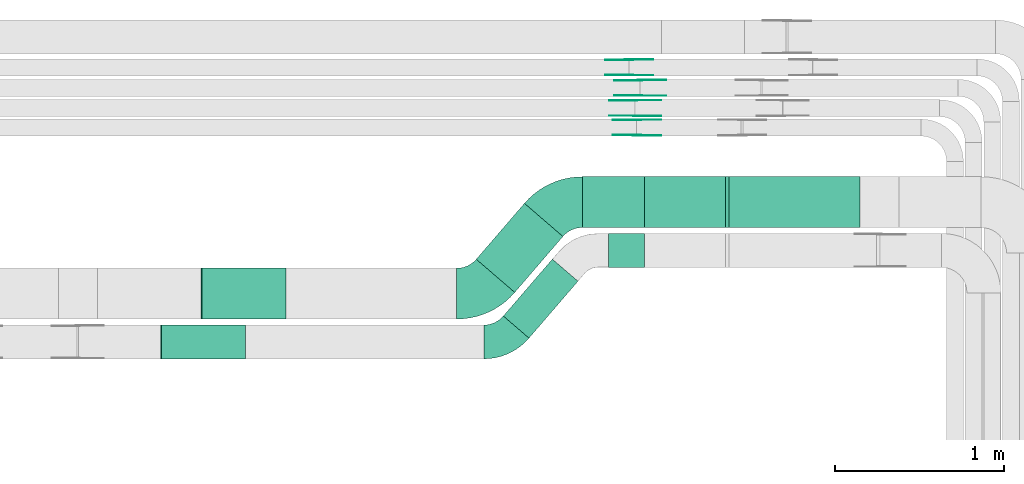
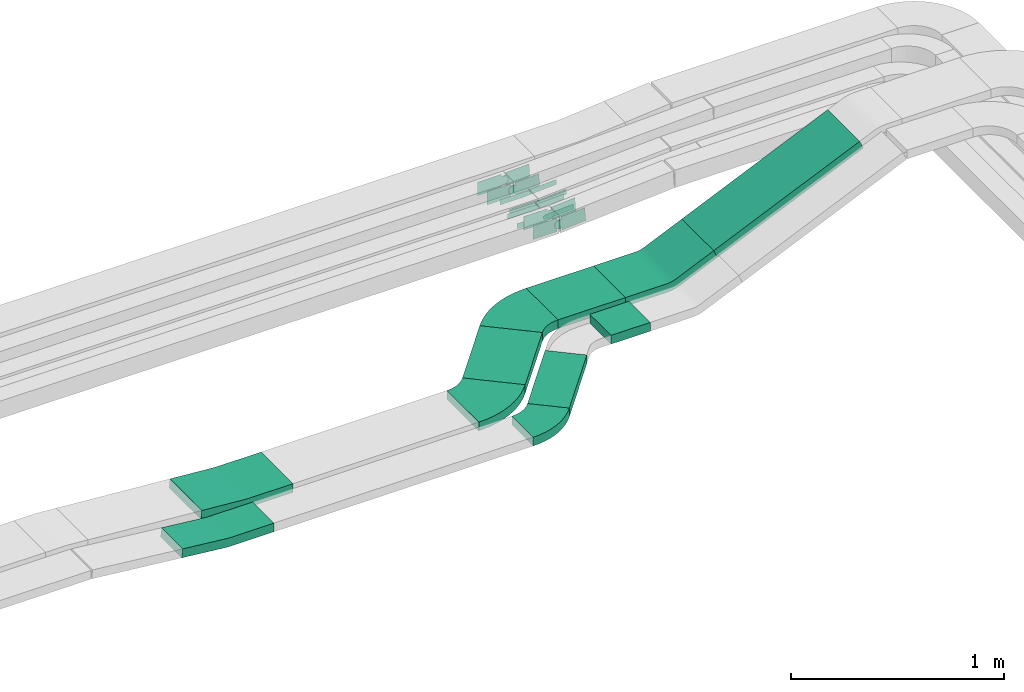
# One storey, part 22 of 31: 22 flow fittings, 5 flow segments.
"""IFC2X3 building model written with IfcOpenShell, lengths in millimetres."""

from ifc_helpers import new_model, entity, si_unit, converted_unit, derived_unit, direction, frame, frame_2d, origin, place, context, subcontext, project, spatial, polyline, circle_curve, parameter, trimmed, segment, composite_curve, rectangle, outline, extrude, source, transform, mapped, material, type_object, type_shapes, element, save


model = new_model("IFC2X3")

# Units and contexts
model_context = context("Model", 3, precision=0.01, world=origin(), true_north=direction((6.12303176911189e-17, 1.0)))
body_context = subcontext(model_context, "Body", "Model", "MODEL_VIEW")
ifc_project = project(units=[si_unit("LENGTHUNIT", "METRE", prefix="MILLI"), si_unit("AREAUNIT", "SQUARE_METRE"), si_unit("VOLUMEUNIT", "CUBIC_METRE"), converted_unit("PLANEANGLEUNIT", "DEGREE", entity("IfcRatioMeasure", 0.0174532925199433), si_unit("PLANEANGLEUNIT", "RADIAN"), dimensions=[0, 0, 0, 0, 0, 0, 0]), si_unit("MASSUNIT", "GRAM", prefix="KILO"), derived_unit("MASSDENSITYUNIT", [(si_unit("MASSUNIT", "GRAM", prefix="KILO"), 1), (si_unit("LENGTHUNIT", "METRE"), -3)]), derived_unit("MOMENTOFINERTIAUNIT", [(si_unit("LENGTHUNIT", "METRE"), 4)]), si_unit("TIMEUNIT", "SECOND"), si_unit("FREQUENCYUNIT", "HERTZ"), si_unit("THERMODYNAMICTEMPERATUREUNIT", "DEGREE_CELSIUS"), derived_unit("THERMALTRANSMITTANCEUNIT", [(si_unit("MASSUNIT", "GRAM", prefix="KILO"), 1), (si_unit("THERMODYNAMICTEMPERATUREUNIT", "KELVIN"), -1), (si_unit("TIMEUNIT", "SECOND"), -3)]), derived_unit("VOLUMETRICFLOWRATEUNIT", [(si_unit("LENGTHUNIT", "METRE"), 3), (si_unit("TIMEUNIT", "SECOND"), -1)]), derived_unit("MASSFLOWRATEUNIT", [(si_unit("MASSUNIT", "GRAM", prefix="KILO"), 1), (si_unit("TIMEUNIT", "SECOND"), -1)]), derived_unit("ROTATIONALFREQUENCYUNIT", [(si_unit("TIMEUNIT", "SECOND"), -1)]), si_unit("ELECTRICCURRENTUNIT", "AMPERE"), si_unit("ELECTRICVOLTAGEUNIT", "VOLT"), si_unit("POWERUNIT", "WATT"), si_unit("FORCEUNIT", "NEWTON", prefix="KILO"), si_unit("ILLUMINANCEUNIT", "LUX"), si_unit("LUMINOUSFLUXUNIT", "LUMEN"), si_unit("LUMINOUSINTENSITYUNIT", "CANDELA"), derived_unit("USERDEFINED", [(si_unit("MASSUNIT", "GRAM", prefix="KILO"), -1), (si_unit("LENGTHUNIT", "METRE"), -2), (si_unit("TIMEUNIT", "SECOND"), 3), (si_unit("LUMINOUSFLUXUNIT", "LUMEN"), 1)]), derived_unit("LINEARVELOCITYUNIT", [(si_unit("LENGTHUNIT", "METRE"), 1), (si_unit("TIMEUNIT", "SECOND"), -1)]), si_unit("PRESSUREUNIT", "PASCAL"), derived_unit("USERDEFINED", [(si_unit("LENGTHUNIT", "METRE"), -2), (si_unit("MASSUNIT", "GRAM", prefix="KILO"), 1), (si_unit("TIMEUNIT", "SECOND"), -2)]), derived_unit("LINEARFORCEUNIT", [(si_unit("MASSUNIT", "GRAM", prefix="KILO"), 1), (si_unit("LENGTHUNIT", "METRE"), 1), (si_unit("TIMEUNIT", "SECOND"), -2), (si_unit("LENGTHUNIT", "METRE"), -1)]), derived_unit("PLANARFORCEUNIT", [(si_unit("MASSUNIT", "GRAM", prefix="KILO"), 1), (si_unit("LENGTHUNIT", "METRE"), 1), (si_unit("TIMEUNIT", "SECOND"), -2), (si_unit("LENGTHUNIT", "METRE"), -2)])], contexts=[model_context])

# Site, building, storey
site_placement = place(None, frame((0.0, -0.00077364408347762, 0.0)))
site = spatial("IfcSite", under=ifc_project, at=site_placement, CompositionType="ELEMENT")
building_placement = place(site_placement, origin())
building = spatial("IfcBuilding", under=site, at=building_placement, CompositionType="ELEMENT")
storey_placement = place(building_placement, frame((0.0, 0.0, 15900.0)))
storey = spatial("IfcBuildingStorey", under=building, at=storey_placement, CompositionType="ELEMENT", Elevation=15900.0)

# Flow segments
cable_carrier_segment_type = type_object("IfcCableCarrierSegmentType", PredefinedType="CABLETRAYSEGMENT")
flow_segment_1_placement = place(storey_placement, frame((57977.730040045, 14975.0255085139, 2510.0)))
element("IfcFlowSegment", 1, at=flow_segment_1_placement, inside=storey, type_object=cable_carrier_segment_type, context=body_context, shape_type="SweptSolid", body=[
    extrude(rectangle(XDim=365.580974619781, YDim=300.000000000001, at=frame_2d((4.33431068813661e-12, -1.08002495835535e-12), x_axis=(1.0, 0.0))), frame((182.790487309981, 150.0, 0.0)), (0.0, 0.0, 1.0), 50.0000000000016),
])
flow_segment_2_placement = place(storey_placement, frame((58129.8647106029, 14740.0255085138, 2510.0)))
element("IfcFlowSegment", 2, at=flow_segment_2_placement, inside=storey, type_object=cable_carrier_segment_type, context=body_context, shape_type="SweptSolid", body=[
    extrude(rectangle(XDim=213.446304058507, YDim=200.000000000002, at=frame_2d((-4.32720526077901e-12, 2.16715534406831e-12), x_axis=(1.0, 0.0))), frame((106.723152029249, 100.0, 1.08286712929839e-09), z_axis=(0.0, 0.0, 1.0), x_axis=(-1.0, 0.0, 0.0)), (0.0, 0.0, 1.0), 50.0000000000016),
])
flow_segment_3_placement = place(storey_placement, frame((58823.1038131155, 14975.0255085139, 2615.53742369649)))
element("IfcFlowSegment", 3, at=flow_segment_3_placement, inside=storey, type_object=cable_carrier_segment_type, context=body_context, shape_type="SweptSolid", body=[
    extrude(rectangle(XDim=50.0000000000058, YDim=300.000000000001, at=frame_2d((0.0, 1.98063787593128e-12), x_axis=(0.0, 1.0))), frame((10.103600774682, 150.0, 22.8673840083723), z_axis=(0.914695360334615, 0.0, 0.404144030986887), x_axis=(0.0, 1.0, 0.0)), (0.0, 0.0, 1.0), 866.474738056523),
])
flow_segment_4_placement = place(storey_placement, frame((57350.8864609675, 14592.1327446923, 2510.0)))
element("IfcFlowSegment", 4, at=flow_segment_4_placement, inside=storey, type_object=cable_carrier_segment_type, context=body_context, shape_type="SweptSolid", body=[
    extrude(rectangle(XDim=435.530076428594, YDim=300.000000000003, at=frame_2d((8.24229573481716e-13, 6.96331881044898e-13), x_axis=(1.0, 0.0))), frame((255.765017222242, 262.892763821559, 0.0), z_axis=(0.0, 0.0, 1.0), x_axis=(-0.652556674980556, -0.757739919720692, 0.0)), (0.0, 0.0, 1.0), 50.0000000000016),
])
flow_segment_5_placement = place(storey_placement, frame((57510.667175223, 14322.3884121903, 2510.0)))
element("IfcFlowSegment", 5, at=flow_segment_5_placement, inside=storey, type_object=cable_carrier_segment_type, context=body_context, shape_type="SweptSolid", body=[
    extrude(rectangle(XDim=443.176120125961, YDim=200.000000000008, at=frame_2d((6.50857145956252e-12, -5.86197757002083e-12), x_axis=(1.0, 0.0))), frame((220.372759662199, 233.161786341315, 0.0), z_axis=(0.0, 0.0, 1.0), x_axis=(0.652556674980505, 0.757739919720736, 0.0)), (0.0, 0.0, 1.0), 50.0000000000016),
])

# Flow fittings
ifc_material_1 = material(Name="G")
cable_carrier_fitting_type_1 = type_object("IfcCableCarrierFittingType", PredefinedType="NOTDEFINED", material=ifc_material_1)
shared_shape_1 = source(origin(), body_context, "Body", "SweptSolid", [
    extrude(outline(composite_curve([segment(trimmed(circle_curve(frame_2d((-44.5901162790698, 0.0), x_axis=(1.0, 0.0)), 12.5), [parameter(90.0000000000007)], [parameter(270.0)], True, "PARAMETER"), True, "CONTINUOUS"), segment(polyline([(-44.5901162790697, -12.5), (-33.0901162790698, -12.5)]), True, "CONTINUOUS"), segment(polyline([(-33.0901162790698, -12.5), (-31.2296511627907, -14.5)]), True, "CONTINUOUS"), segment(polyline([(-31.2296511627907, -14.5), (108.90988372093, -14.5)]), True, "CONTINUOUS"), segment(polyline([(108.90988372093, -14.5), (108.90988372093, 14.5)]), True, "CONTINUOUS"), segment(polyline([(108.90988372093, 14.5), (-31.2296511627907, 14.5)]), True, "CONTINUOUS"), segment(polyline([(-31.2296511627907, 14.5), (-33.0901162790698, 12.5)]), True, "CONTINUOUS"), segment(polyline([(-33.0901162790698, 12.5), (-44.5901162790699, 12.5)]), True, "CONTINUOUS")], self_intersect=False)), frame((44.5901162790698, 0.0, 0.0), z_axis=(0.0, 0.0, -1.0), x_axis=(1.0, 0.0, 0.0)), (0.0, 0.0, -1.0), 2.0),
])
type_shapes(cable_carrier_fitting_type_1, [shared_shape_1])
for number, where, z_axis, x_axis in (
    (6, (58317.8212949036, 15753.9980000417, 2642.36207118772), (0.0, -1.0, 0.0), (0.998226574623013, 0.0, 0.0595290325505655)),
    (7, (58289.0709615996, 15633.9980000417, 2642.36325714285), (0.0, -1.0, 0.0), (0.998794992173109, 0.0, 0.0490771190058922)),
):
    element("IfcFlowFitting", number, at=place(storey_placement, frame(where, z_axis=z_axis, x_axis=x_axis)), inside=storey, type_object=cable_carrier_fitting_type_1, material=ifc_material_1, context=body_context, shape_type="MappedRepresentation", body=[
        mapped(shared_shape_1, transform((0.0, 0.0, 0.0), scale=1.0)),
    ])
cable_carrier_fitting_type_2 = type_object("IfcCableCarrierFittingType", PredefinedType="NOTDEFINED", material=ifc_material_1)
shared_shape_2 = source(origin(), body_context, "Body", "SweptSolid", [
    extrude(outline(composite_curve([segment(trimmed(circle_curve(frame_2d((-44.5901162790697, 0.0), x_axis=(1.0, 0.0)), 12.5), [parameter(90.0000000000007)], [parameter(270.0)], True, "PARAMETER"), True, "CONTINUOUS"), segment(polyline([(-44.5901162790697, -12.5), (-33.0901162790697, -12.5)]), True, "CONTINUOUS"), segment(polyline([(-33.0901162790697, -12.5), (-31.2296511627907, -14.5)]), True, "CONTINUOUS"), segment(polyline([(-31.2296511627907, -14.5), (108.90988372093, -14.5)]), True, "CONTINUOUS"), segment(polyline([(108.90988372093, -14.5), (108.90988372093, 14.5)]), True, "CONTINUOUS"), segment(polyline([(108.90988372093, 14.5), (-31.2296511627907, 14.5)]), True, "CONTINUOUS"), segment(polyline([(-31.2296511627907, 14.5), (-33.0901162790698, 12.5)]), True, "CONTINUOUS"), segment(polyline([(-33.0901162790698, 12.5), (-44.5901162790699, 12.5)]), True, "CONTINUOUS")], self_intersect=False)), frame((44.5901162790697, 0.0, 0.0)), (0.0, 0.0, 1.0), 2.0),
])
type_shapes(cable_carrier_fitting_type_2, [shared_shape_2])
for number, where, z_axis, x_axis in (
    (8, (58317.8212949036, 15844.918000062, 2642.36207118771), (0.0, 1.0, 0.0), (0.998226574623013, 0.0, 0.0595290325505655)),
    (9, (58289.0709615996, 15724.918000062, 2642.36325714285), (0.0, 1.0, 0.0), (0.998794992173109, 0.0, 0.0490771190058922)),
):
    element("IfcFlowFitting", number, at=place(storey_placement, frame(where, z_axis=z_axis, x_axis=x_axis)), inside=storey, type_object=cable_carrier_fitting_type_2, material=ifc_material_1, context=body_context, shape_type="MappedRepresentation", body=[
        mapped(shared_shape_2, transform((0.0, 0.0, 0.0), scale=1.0)),
    ])
cable_carrier_fitting_type_3 = type_object("IfcCableCarrierFittingType", PredefinedType="NOTDEFINED", material=ifc_material_1)
shared_shape_3 = source(origin(), body_context, "Body", "SweptSolid", [
    extrude(outline(composite_curve([segment(trimmed(circle_curve(frame_2d((-44.5901162790698, 0.0), x_axis=(1.0, 0.0)), 12.5), [parameter(90.0000000000007)], [parameter(270.0)], True, "PARAMETER"), True, "CONTINUOUS"), segment(polyline([(-44.5901162790697, -12.5), (-33.0901162790698, -12.5)]), True, "CONTINUOUS"), segment(polyline([(-33.0901162790698, -12.5), (-31.2296511627907, -14.5)]), True, "CONTINUOUS"), segment(polyline([(-31.2296511627907, -14.5), (108.90988372093, -14.5)]), True, "CONTINUOUS"), segment(polyline([(108.90988372093, -14.5), (108.90988372093, 14.5)]), True, "CONTINUOUS"), segment(polyline([(108.90988372093, 14.5), (-31.2296511627907, 14.5)]), True, "CONTINUOUS"), segment(polyline([(-31.2296511627907, 14.5), (-33.0901162790698, 12.5)]), True, "CONTINUOUS"), segment(polyline([(-33.0901162790698, 12.5), (-44.5901162790699, 12.5)]), True, "CONTINUOUS")], self_intersect=False)), frame((44.5901162790698, 0.0, 0.0), z_axis=(0.0, 0.0, -1.0), x_axis=(1.0, 0.0, 0.0)), (0.0, 0.0, -1.0), 2.0),
])
type_shapes(cable_carrier_fitting_type_3, [shared_shape_3])
for number, where, z_axis, x_axis in (
    (10, (58317.8212949036, 15842.918000062, 2642.36207118772), (0.0, 1.0, 0.0), (-1.0, 0.0, 0.0)),
    (11, (58289.0709615996, 15722.918000062, 2642.36325714285), (0.0, 1.0, 0.0), (-1.0, 0.0, 0.0)),
):
    element("IfcFlowFitting", number, at=place(storey_placement, frame(where, z_axis=z_axis, x_axis=x_axis)), inside=storey, type_object=cable_carrier_fitting_type_3, material=ifc_material_1, context=body_context, shape_type="MappedRepresentation", body=[
        mapped(shared_shape_3, transform((0.0, 0.0, 0.0), scale=1.0)),
    ])
cable_carrier_fitting_type_4 = type_object("IfcCableCarrierFittingType", PredefinedType="NOTDEFINED", material=ifc_material_1)
shared_shape_4 = source(origin(), body_context, "Body", "SweptSolid", [
    extrude(outline(composite_curve([segment(trimmed(circle_curve(frame_2d((-44.5901162790697, 0.0), x_axis=(1.0, 0.0)), 12.5), [parameter(90.0000000000007)], [parameter(270.0)], True, "PARAMETER"), True, "CONTINUOUS"), segment(polyline([(-44.5901162790697, -12.5), (-33.0901162790697, -12.5)]), True, "CONTINUOUS"), segment(polyline([(-33.0901162790697, -12.5), (-31.2296511627907, -14.5)]), True, "CONTINUOUS"), segment(polyline([(-31.2296511627907, -14.5), (108.90988372093, -14.5)]), True, "CONTINUOUS"), segment(polyline([(108.90988372093, -14.5), (108.90988372093, 14.5)]), True, "CONTINUOUS"), segment(polyline([(108.90988372093, 14.5), (-31.2296511627907, 14.5)]), True, "CONTINUOUS"), segment(polyline([(-31.2296511627907, 14.5), (-33.0901162790698, 12.5)]), True, "CONTINUOUS"), segment(polyline([(-33.0901162790698, 12.5), (-44.5901162790699, 12.5)]), True, "CONTINUOUS")], self_intersect=False)), frame((44.5901162790697, 0.0, 0.0)), (0.0, 0.0, 1.0), 2.0),
])
type_shapes(cable_carrier_fitting_type_4, [shared_shape_4])
for number, where, z_axis, x_axis in (
    (12, (58317.8212949036, 15755.9980000417, 2642.36207118772), (0.0, -1.0, 0.0), (-1.0, 0.0, 0.0)),
    (13, (58289.0709615996, 15635.9980000417, 2642.36325714286), (0.0, -1.0, 0.0), (-1.0, 0.0, 0.0)),
):
    element("IfcFlowFitting", number, at=place(storey_placement, frame(where, z_axis=z_axis, x_axis=x_axis)), inside=storey, type_object=cable_carrier_fitting_type_4, material=ifc_material_1, context=body_context, shape_type="MappedRepresentation", body=[
        mapped(shared_shape_4, transform((0.0, 0.0, 0.0), scale=1.0)),
    ])
cable_carrier_fitting_type_5 = type_object("IfcCableCarrierFittingType", PredefinedType="NOTDEFINED", material=ifc_material_1)
shared_shape_5 = source(origin(), body_context, "Body", "SweptSolid", [
    extrude(outline(composite_curve([segment(trimmed(circle_curve(frame_2d((-41.4651162790697, 0.0), x_axis=(1.0, 0.0)), 25.0), [parameter(90.0000000000007)], [parameter(270.0)], True, "PARAMETER"), True, "CONTINUOUS"), segment(polyline([(-41.4651162790697, -25.0), (-29.9651162790697, -25.0)]), True, "CONTINUOUS"), segment(polyline([(-29.9651162790697, -25.0), (-28.1046511627907, -38.5)]), True, "CONTINUOUS"), segment(polyline([(-28.1046511627907, -38.5), (99.5348837209303, -38.5)]), True, "CONTINUOUS"), segment(polyline([(99.5348837209303, -38.5), (99.5348837209303, 38.5)]), True, "CONTINUOUS"), segment(polyline([(99.5348837209303, 38.5), (-28.1046511627907, 38.5)]), True, "CONTINUOUS"), segment(polyline([(-28.1046511627907, 38.5), (-29.9651162790697, 25.0)]), True, "CONTINUOUS"), segment(polyline([(-29.9651162790697, 25.0), (-41.46511627907, 25.0)]), True, "CONTINUOUS")], self_intersect=False)), frame((41.4651162790697, 0.0, 0.0), z_axis=(0.0, 0.0, -1.0), x_axis=(1.0, 0.0, 0.0)), (0.0, 0.0, -1.0), 2.0),
])
type_shapes(cable_carrier_fitting_type_5, [shared_shape_5])
for number, where, z_axis, x_axis in (
    (14, (58298.4870270344, 15519.5339089845, 2667.02711976825), (0.0, -1.0, 0.0), (0.997626423978682, 0.0, 0.0688586826733382)),
    (15, (58253.3584591761, 15874.5339089845, 2665.0), (0.0, -1.0, 0.0), (0.999143050018218, 0.0, 0.0413904046886741)),
):
    element("IfcFlowFitting", number, at=place(storey_placement, frame(where, z_axis=z_axis, x_axis=x_axis)), inside=storey, type_object=cable_carrier_fitting_type_5, material=ifc_material_1, context=body_context, shape_type="MappedRepresentation", body=[
        mapped(shared_shape_5, transform((0.0, 0.0, 0.0), scale=1.0)),
    ])
cable_carrier_fitting_type_6 = type_object("IfcCableCarrierFittingType", PredefinedType="NOTDEFINED", material=ifc_material_1)
shared_shape_6 = source(origin(), body_context, "Body", "SweptSolid", [
    extrude(outline(composite_curve([segment(trimmed(circle_curve(frame_2d((-41.4651162790697, 0.0), x_axis=(1.0, 0.0)), 25.0), [parameter(90.0000000000007)], [parameter(270.0)], True, "PARAMETER"), True, "CONTINUOUS"), segment(polyline([(-41.4651162790697, -25.0), (-29.9651162790697, -25.0)]), True, "CONTINUOUS"), segment(polyline([(-29.9651162790697, -25.0), (-28.1046511627907, -38.5)]), True, "CONTINUOUS"), segment(polyline([(-28.1046511627907, -38.5), (99.5348837209303, -38.5)]), True, "CONTINUOUS"), segment(polyline([(99.5348837209303, -38.5), (99.5348837209303, 38.5)]), True, "CONTINUOUS"), segment(polyline([(99.5348837209303, 38.5), (-28.1046511627907, 38.5)]), True, "CONTINUOUS"), segment(polyline([(-28.1046511627907, 38.5), (-29.9651162790697, 25.0)]), True, "CONTINUOUS"), segment(polyline([(-29.9651162790697, 25.0), (-41.46511627907, 25.0)]), True, "CONTINUOUS")], self_intersect=False)), frame((41.4651162790697, 0.0, 0.0)), (0.0, 0.0, 1.0), 2.0),
])
type_shapes(cable_carrier_fitting_type_6, [shared_shape_6])
for number, where, z_axis, x_axis in (
    (16, (58298.4870270344, 15610.4539090048, 2667.02711976825), (0.0, 1.0, 0.0), (0.997626423978682, 0.0, 0.0688586826733382)),
    (17, (58253.3584591761, 15965.4539090048, 2665.0), (0.0, 1.0, 0.0), (0.999143050018218, 0.0, 0.0413904046886741)),
):
    element("IfcFlowFitting", number, at=place(storey_placement, frame(where, z_axis=z_axis, x_axis=x_axis)), inside=storey, type_object=cable_carrier_fitting_type_6, material=ifc_material_1, context=body_context, shape_type="MappedRepresentation", body=[
        mapped(shared_shape_6, transform((0.0, 0.0, 0.0), scale=1.0)),
    ])
cable_carrier_fitting_type_7 = type_object("IfcCableCarrierFittingType", PredefinedType="NOTDEFINED", material=ifc_material_1)
shared_shape_7 = source(origin(), body_context, "Body", "SweptSolid", [
    extrude(outline(composite_curve([segment(trimmed(circle_curve(frame_2d((-41.4651162790697, 0.0), x_axis=(1.0, 0.0)), 25.0), [parameter(90.0000000000007)], [parameter(270.0)], True, "PARAMETER"), True, "CONTINUOUS"), segment(polyline([(-41.4651162790697, -25.0), (-29.9651162790697, -25.0)]), True, "CONTINUOUS"), segment(polyline([(-29.9651162790697, -25.0), (-28.1046511627907, -38.5)]), True, "CONTINUOUS"), segment(polyline([(-28.1046511627907, -38.5), (99.5348837209303, -38.5)]), True, "CONTINUOUS"), segment(polyline([(99.5348837209303, -38.5), (99.5348837209303, 38.5)]), True, "CONTINUOUS"), segment(polyline([(99.5348837209303, 38.5), (-28.1046511627907, 38.5)]), True, "CONTINUOUS"), segment(polyline([(-28.1046511627907, 38.5), (-29.9651162790697, 25.0)]), True, "CONTINUOUS"), segment(polyline([(-29.9651162790697, 25.0), (-41.46511627907, 25.0)]), True, "CONTINUOUS")], self_intersect=False)), frame((41.4651162790697, 0.0, 0.0), z_axis=(0.0, 0.0, -1.0), x_axis=(1.0, 0.0, 0.0)), (0.0, 0.0, -1.0), 2.0),
])
type_shapes(cable_carrier_fitting_type_7, [shared_shape_7])
for number, where, z_axis, x_axis in (
    (18, (58298.4870270344, 15608.4539090048, 2667.02711976825), (0.0, 1.0, 0.0), (-1.0, 0.0, 0.0)),
    (19, (58253.3584591761, 15963.4539090048, 2665.0), (0.0, 1.0, 0.0), (-1.0, 0.0, 0.0)),
):
    element("IfcFlowFitting", number, at=place(storey_placement, frame(where, z_axis=z_axis, x_axis=x_axis)), inside=storey, type_object=cable_carrier_fitting_type_7, material=ifc_material_1, context=body_context, shape_type="MappedRepresentation", body=[
        mapped(shared_shape_7, transform((0.0, 0.0, 0.0), scale=1.0)),
    ])
cable_carrier_fitting_type_8 = type_object("IfcCableCarrierFittingType", PredefinedType="NOTDEFINED", material=ifc_material_1)
shared_shape_8 = source(origin(), body_context, "Body", "SweptSolid", [
    extrude(outline(composite_curve([segment(trimmed(circle_curve(frame_2d((-41.4651162790697, 0.0), x_axis=(1.0, 0.0)), 25.0), [parameter(90.0000000000007)], [parameter(270.0)], True, "PARAMETER"), True, "CONTINUOUS"), segment(polyline([(-41.4651162790697, -25.0), (-29.9651162790697, -25.0)]), True, "CONTINUOUS"), segment(polyline([(-29.9651162790697, -25.0), (-28.1046511627907, -38.5)]), True, "CONTINUOUS"), segment(polyline([(-28.1046511627907, -38.5), (99.5348837209303, -38.5)]), True, "CONTINUOUS"), segment(polyline([(99.5348837209303, -38.5), (99.5348837209303, 38.5)]), True, "CONTINUOUS"), segment(polyline([(99.5348837209303, 38.5), (-28.1046511627907, 38.5)]), True, "CONTINUOUS"), segment(polyline([(-28.1046511627907, 38.5), (-29.9651162790697, 25.0)]), True, "CONTINUOUS"), segment(polyline([(-29.9651162790697, 25.0), (-41.46511627907, 25.0)]), True, "CONTINUOUS")], self_intersect=False)), frame((41.4651162790697, 0.0, 0.0)), (0.0, 0.0, 1.0), 2.0),
])
type_shapes(cable_carrier_fitting_type_8, [shared_shape_8])
for number, where, z_axis, x_axis in (
    (20, (58298.4870270344, 15521.5339089845, 2667.02711976826), (0.0, -1.0, 0.0), (-1.0, 0.0, 0.0)),
    (21, (58253.3584591761, 15876.5339089845, 2665.0), (0.0, -1.0, 0.0), (-1.0, 0.0, 0.0)),
):
    element("IfcFlowFitting", number, at=place(storey_placement, frame(where, z_axis=z_axis, x_axis=x_axis)), inside=storey, type_object=cable_carrier_fitting_type_8, material=ifc_material_1, context=body_context, shape_type="MappedRepresentation", body=[
        mapped(shared_shape_8, transform((0.0, 0.0, 0.0), scale=1.0)),
    ])
ifc_material_2 = material()
cable_carrier_fitting_type_9 = type_object("IfcCableCarrierFittingType", Name="470_DKC_S5_CS 90 internal vertical angle:-", PredefinedType="NOTDEFINED", material=ifc_material_2)
shared_shape_9 = source(origin(), body_context, "Body", "SweptSolid", [
    extrude(outline(composite_curve([segment(polyline([(-249.037255392585, -31.5786089903381), (-6.85999677575405, -31.5786089903381)]), True, "CONTINUOUS"), segment(trimmed(circle_curve(frame_2d((-6.85999677575435, 133.421391009661), x_axis=(0.0, -1.0)), 164.999999999999), [parameter(0.0)], [parameter(5.88665809159337)], True, "PARAMETER"), True, "CONTINUOUS"), segment(polyline([(10.0625529246975, -30.7085188533358), (250.962744607415, -5.87059948810881)]), True, "CONTINUOUS"), segment(polyline([(250.962744607415, -5.87059948810881), (245.834699243642, 43.865736834012)]), True, "CONTINUOUS"), segment(polyline([(245.834699243642, 43.865736834012), (4.93450756092417, 19.027817468785)]), True, "CONTINUOUS"), segment(trimmed(circle_curve(frame_2d((-6.85999677575435, 133.421391009661), x_axis=(0.0, -1.0)), 114.999999999999), [parameter(0.0)], [parameter(5.88665809159337)], True, "PARAMETER"), False, "CONTINUOUS"), segment(polyline([(-6.85999677575405, 18.4213910096621), (-249.037255392585, 18.4213910096621)]), True, "CONTINUOUS"), segment(polyline([(-249.037255392585, 18.4213910096621), (-249.037255392585, -31.5786089903381)]), True, "CONTINUOUS")], self_intersect=False)), frame((-0.338245884861129, 6.57860899033081, -100.0)), (0.0, 0.0, 1.0), 200.0),
])
type_shapes(cable_carrier_fitting_type_9, [shared_shape_9])
flow_fitting_1_placement = place(storey_placement, frame((55738.383738638, 14300.0255085138, 2535.0), z_axis=(0.0, 1.0, 0.0), x_axis=(-1.0, 0.0, 0.0)))
element("IfcFlowFitting", 22, at=flow_fitting_1_placement, inside=storey, type_object=cable_carrier_fitting_type_9, material=ifc_material_2, Name="470_DKC_S5_CS 90 internal vertical angle:-", ObjectType="470_DKC_S5_CS 90 internal vertical angle:-", context=body_context, shape_type="MappedRepresentation", body=[
    mapped(shared_shape_9, transform((0.0, 0.0, 0.0), scale=1.0)),
])
cable_carrier_fitting_type_10 = type_object("IfcCableCarrierFittingType", Name="470_DKC_S5_CS 90 internal vertical angle:-", PredefinedType="NOTDEFINED", material=ifc_material_2)
shared_shape_10 = source(origin(), body_context, "Body", "SweptSolid", [
    extrude(outline(composite_curve([segment(polyline([(-249.213762110834, -29.9452923668549), (-5.24936575578128, -29.9452923668549)]), True, "CONTINUOUS"), segment(trimmed(circle_curve(frame_2d((-5.24936575578151, 135.054707633144), x_axis=(0.0, -1.0)), 164.999999999999), [parameter(0.0)], [parameter(4.45175416363027)], True, "PARAMETER"), True, "CONTINUOUS"), segment(polyline([(7.55787073102793, -29.4474950681286), (250.786237889166, -10.5110725318811)]), True, "CONTINUOUS"), segment(polyline([(250.786237889166, -10.5110725318811), (246.905257135587, 39.3380798018384)]), True, "CONTINUOUS"), segment(polyline([(246.905257135587, 39.3380798018384), (3.67688997744924, 20.401657265591)]), True, "CONTINUOUS"), segment(trimmed(circle_curve(frame_2d((-5.24936575578151, 135.054707633144), x_axis=(0.0, -1.0)), 114.999999999999), [parameter(0.0)], [parameter(4.45175416363027)], True, "PARAMETER"), False, "CONTINUOUS"), segment(polyline([(-5.24936575578128, 20.0547076331453), (-249.213762110834, 20.0547076331453)]), True, "CONTINUOUS"), segment(polyline([(-249.213762110834, 20.0547076331453), (-249.213762110834, -29.9452923668549)]), True, "CONTINUOUS")], self_intersect=False)), frame((-0.192215798002422, 4.94529236684768, -150.0)), (0.0, 0.0, 1.0), 300.0),
])
type_shapes(cable_carrier_fitting_type_10, [shared_shape_10])
flow_fitting_2_placement = place(storey_placement, frame((55978.3837386381, 14585.0255085139, 2535.0), z_axis=(0.0, -1.0, 0.0), x_axis=(0.996983046674385, 0.0, -0.077619615071584)))
element("IfcFlowFitting", 23, at=flow_fitting_2_placement, inside=storey, type_object=cable_carrier_fitting_type_10, material=ifc_material_2, Name="470_DKC_S5_CS 90 internal vertical angle:-", ObjectType="470_DKC_S5_CS 90 internal vertical angle:-", context=body_context, shape_type="MappedRepresentation", body=[
    mapped(shared_shape_10, transform((0.0, 0.0, 0.0), scale=1.0)),
])
cable_carrier_fitting_type_11 = type_object("IfcCableCarrierFittingType", Name="470_DKC_S5_CS 90 internal vertical angle:-", PredefinedType="NOTDEFINED", material=ifc_material_2)
shared_shape_11 = source(origin(), body_context, "Body", "SweptSolid", [
    extrude(outline(composite_curve([segment(polyline([(-249.774539881194, -53.8368643145079), (-23.4637419005461, -53.8368643145079)]), True, "CONTINUOUS"), segment(trimmed(circle_curve(frame_2d((-23.4637419005464, 111.163135685491), x_axis=(0.0, -1.0)), 164.999999999999), [parameter(0.0)], [parameter(23.8374988354048)], True, "PARAMETER"), True, "CONTINUOUS"), segment(polyline([(43.2200232122734, -39.7615987697265), (250.225460118806, 51.700559382009)]), True, "CONTINUOUS"), segment(polyline([(250.225460118806, 51.7005593820089), (230.018258569466, 97.4353273987422)]), True, "CONTINUOUS"), segment(polyline([(230.018258569466, 97.4353273987421), (23.0128216629338, 5.97316924700662)]), True, "CONTINUOUS"), segment(trimmed(circle_curve(frame_2d((-23.4637419005464, 111.163135685491), x_axis=(0.0, -1.0)), 114.999999999999), [parameter(0.0)], [parameter(23.8374988354048)], True, "PARAMETER"), False, "CONTINUOUS"), segment(polyline([(-23.4637419005461, -3.83686431450762), (-249.774539881194, -3.8368643145076)]), True, "CONTINUOUS"), segment(polyline([(-249.774539881194, -3.8368643145076), (-249.774539881194, -53.8368643145079)]), True, "CONTINUOUS")], self_intersect=False)), frame((-6.08673673446955, 28.8368643145006, -150.0)), (0.0, 0.0, 1.0), 300.0),
])
type_shapes(cable_carrier_fitting_type_11, [shared_shape_11])
flow_fitting_3_placement = place(storey_placement, frame((58599.1722912805, 15125.0255085139, 2535.0), z_axis=(0.0, -1.0, 0.0), x_axis=(1.0, 0.0, 0.0)))
element("IfcFlowFitting", 24, at=flow_fitting_3_placement, inside=storey, type_object=cable_carrier_fitting_type_11, material=ifc_material_2, Name="470_DKC_S5_CS 90 internal vertical angle:-", ObjectType="470_DKC_S5_CS 90 internal vertical angle:-", context=body_context, shape_type="MappedRepresentation", body=[
    mapped(shared_shape_11, transform((0.0, 0.0, 0.0), scale=1.0)),
])
cable_carrier_fitting_type_12 = type_object("IfcCableCarrierFittingType", Name="470_DKC_S5_Variable Angle Elbow 0-45:-", PredefinedType="NOTDEFINED", material=ifc_material_2)
shared_shape_12 = source(origin(), body_context, "Body", "SweptSolid", [
    extrude(outline(composite_curve([segment(polyline([(-114.574127126839, -202.305933732841), (-113.574127126838, -202.305933732841)]), True, "CONTINUOUS"), segment(trimmed(circle_curve(frame_2d((-113.574127126846, 247.694066267159), x_axis=(0.0, -1.0)), 450.0), [parameter(0.0)], [parameter(49.265357282271)], True, "PARAMETER"), True, "CONTINUOUS"), segment(polyline([(227.408836747449, -45.9564374741093), (228.061393422429, -45.198697554389)]), True, "CONTINUOUS"), segment(polyline([(228.061393422429, -45.1986975543891), (0.739417506233099, 150.568304939791)]), True, "CONTINUOUS"), segment(polyline([(0.739417506233135, 150.568304939791), (0.0868608312521478, 149.81056502007)]), True, "CONTINUOUS"), segment(trimmed(circle_curve(frame_2d((-113.574127126846, 247.694066267159), x_axis=(0.0, -1.0)), 150.0), [parameter(0.0)], [parameter(49.265357282271)], True, "PARAMETER"), False, "CONTINUOUS"), segment(polyline([(-113.574127126843, 97.6940662671592), (-114.574127126845, 97.6940662671592)]), True, "CONTINUOUS"), segment(polyline([(-114.574127126845, 97.6940662671592), (-114.574127126839, -202.305933732841)]), True, "CONTINUOUS")], self_intersect=False)), frame((-23.9836216377167, 52.3059337328307, -25.0)), (0.0, 0.0, 1.0), 49.9999999999981),
])
type_shapes(cable_carrier_fitting_type_12, [shared_shape_12])
flow_fitting_4_placement = place(storey_placement, frame((57839.1722912805, 15125.0255085138, 2535.0), z_axis=(0.0, 0.0, 1.0), x_axis=(-1.0, 0.0, 0.0)))
element("IfcFlowFitting", 25, at=flow_fitting_4_placement, inside=storey, type_object=cable_carrier_fitting_type_12, material=ifc_material_2, Name="470_DKC_S5_Variable Angle Elbow 0-45:-", ObjectType="470_DKC_S5_Variable Angle Elbow 0-45:-", context=body_context, shape_type="MappedRepresentation", body=[
    mapped(shared_shape_12, transform((0.0, 0.0, 0.0), scale=1.0)),
])
flow_fitting_5_placement = place(storey_placement, frame((57374.130665099, 14585.0255085138, 2535.0)))
element("IfcFlowFitting", 26, at=flow_fitting_5_placement, inside=storey, type_object=cable_carrier_fitting_type_12, material=ifc_material_2, Name="470_DKC_S5_Variable Angle Elbow 0-45:-", ObjectType="470_DKC_S5_Variable Angle Elbow 0-45:-", context=body_context, shape_type="MappedRepresentation", body=[
    mapped(shared_shape_12, transform((0.0, 0.0, 0.0), scale=1.0)),
])
cable_carrier_fitting_type_13 = type_object("IfcCableCarrierFittingType", Name="470_DKC_S5_Variable Angle Elbow 0-45:-", PredefinedType="NOTDEFINED", material=ifc_material_2)
shared_shape_13 = source(origin(), body_context, "Body", "SweptSolid", [
    extrude(outline(composite_curve([segment(polyline([(-95.6306291338349, -143.619850607359), (-94.6306291338335, -143.619850607359)]), True, "CONTINUOUS"), segment(trimmed(circle_curve(frame_2d((-94.6306291338282, 206.380149392641), x_axis=(0.0, -1.0)), 350.0), [parameter(0.0)], [parameter(49.2653572822751)], True, "PARAMETER"), True, "CONTINUOUS"), segment(polyline([(170.57834276841, -22.0146868505582), (171.23089944339, -21.2569469308377)]), True, "CONTINUOUS"), segment(polyline([(171.23089944339, -21.2569469308377), (19.6829154992547, 109.254388065276)]), True, "CONTINUOUS"), segment(polyline([(19.6829154992547, 109.254388065276), (19.0303588242739, 108.496648145555)]), True, "CONTINUOUS"), segment(trimmed(circle_curve(frame_2d((-94.6306291338282, 206.380149392641), x_axis=(0.0, -1.0)), 150.0), [parameter(0.0)], [parameter(49.2653572822751)], True, "PARAMETER"), False, "CONTINUOUS"), segment(polyline([(-94.6306291338301, 56.3801493926407), (-95.6306291338315, 56.3801493926408)]), True, "CONTINUOUS"), segment(polyline([(-95.6306291338315, 56.3801493926408), (-95.6306291338349, -143.619850607359)]), True, "CONTINUOUS")], self_intersect=False)), frame((-20.0008281699765, 43.6198506073527, -25.0)), (0.0, 0.0, 1.0), 50.0000000000008),
])
type_shapes(cable_carrier_fitting_type_13, [shared_shape_13])
flow_fitting_6_placement = place(storey_placement, frame((57510.9850878937, 14300.0255085138, 2535.0)))
element("IfcFlowFitting", 27, at=flow_fitting_6_placement, inside=storey, type_object=cable_carrier_fitting_type_13, material=ifc_material_2, Name="470_DKC_S5_Variable Angle Elbow 0-45:-", ObjectType="470_DKC_S5_Variable Angle Elbow 0-45:-", context=body_context, shape_type="MappedRepresentation", body=[
    mapped(shared_shape_13, transform((0.0, 0.0, 0.0), scale=1.0)),
])

save(model, "model.ifc")
